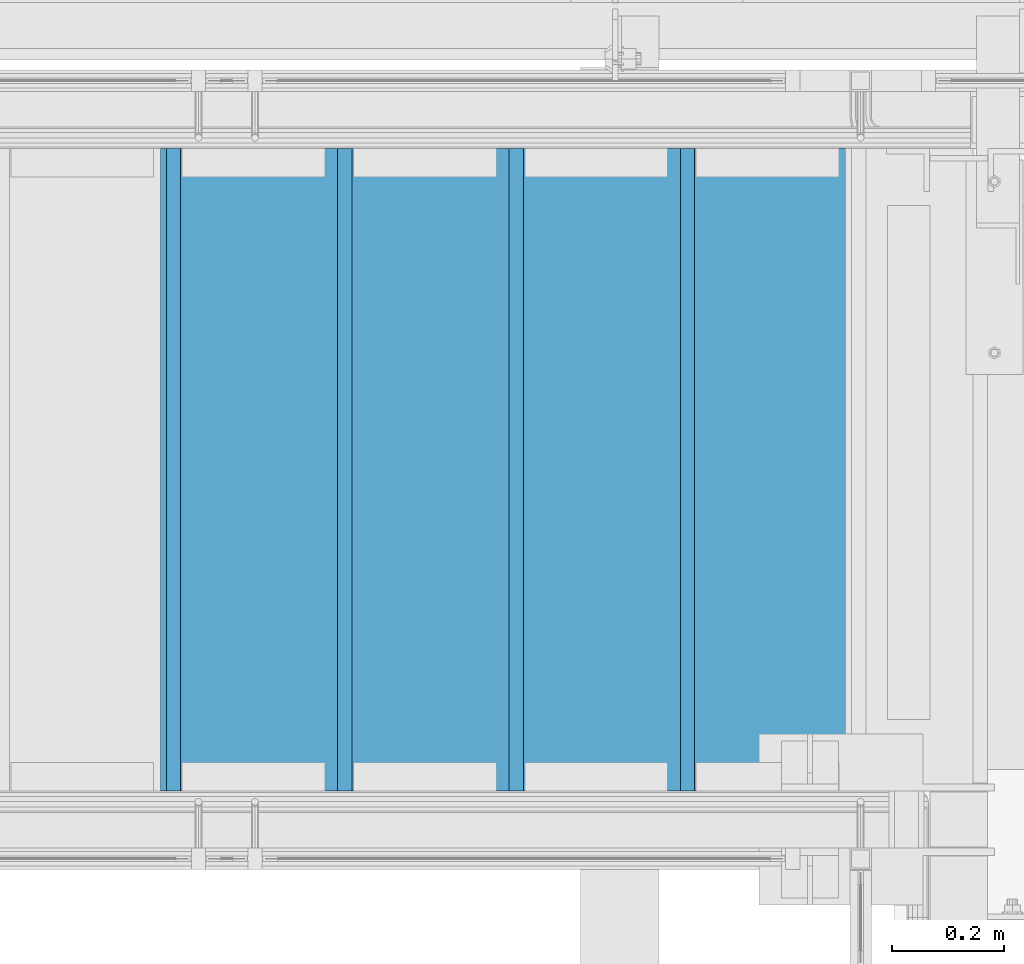
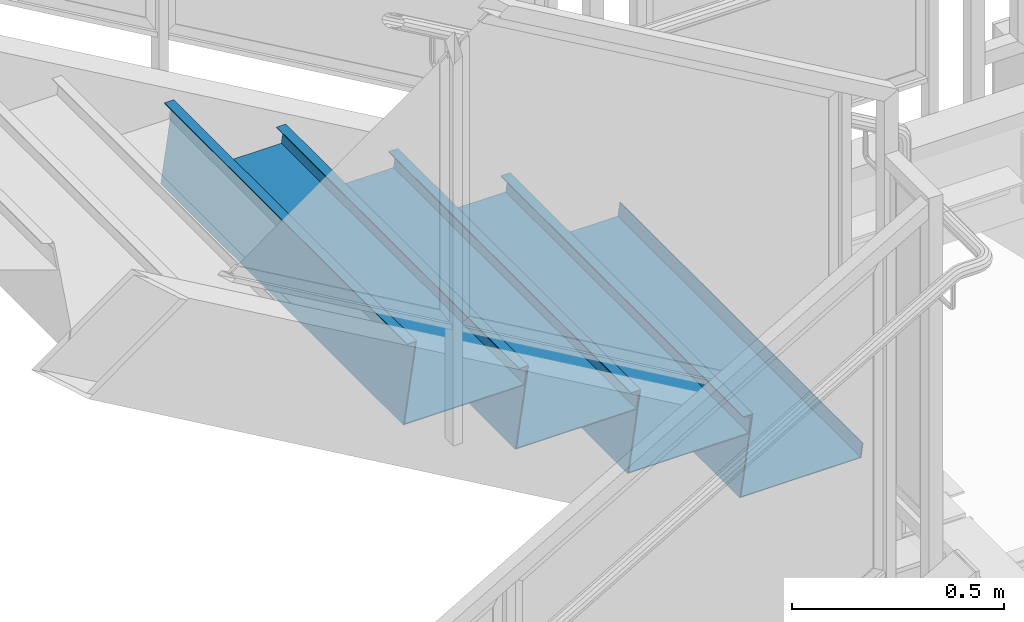
# One storey, part 796 of 1179: 4 beams, 1 element without a shape of its own.
"""IFC2X3 building model written with IfcOpenShell, lengths in millimetres."""

from ifc_helpers import new_model, si_unit, frame, origin_with_axes, place, context, subcontext, project, spatial, faceted_brep, material, type_object, element, aggregate, save


model = new_model("IFC2X3")

# Units and contexts
model_context = context("Model", 3, precision=1e-05, world=origin_with_axes())
body_context = subcontext(model_context, "Body", "Model", "MODEL_VIEW")
ifc_project = project(units=[si_unit("LENGTHUNIT", "METRE", prefix="MILLI"), si_unit("AREAUNIT", "SQUARE_METRE"), si_unit("VOLUMEUNIT", "CUBIC_METRE"), si_unit("MASSUNIT", "GRAM", prefix="KILO"), si_unit("TIMEUNIT", "SECOND"), si_unit("PLANEANGLEUNIT", "RADIAN"), si_unit("SOLIDANGLEUNIT", "STERADIAN"), si_unit("THERMODYNAMICTEMPERATUREUNIT", "DEGREE_CELSIUS"), si_unit("LUMINOUSINTENSITYUNIT", "LUMEN")], contexts=[model_context])

# Site, building, storey
site_placement = place(None, origin_with_axes())
site = spatial("IfcSite", under=ifc_project, at=site_placement, CompositionType="ELEMENT")
building_placement = place(site_placement, origin_with_axes())
building = spatial("IfcBuilding", under=site, at=building_placement, Name="Undefined", CompositionType="ELEMENT")
storey_placement = place(building_placement, origin_with_axes())
storey = spatial("IfcBuildingStorey", under=building, at=storey_placement, Name="Undefined", CompositionType="ELEMENT", Elevation=0.0)

# Assembly, beams
assembly_placement = place(storey_placement, origin_with_axes())
assembly = element("IfcElementAssembly", 1, at=assembly_placement, inside=storey, Name="STAIR", AssemblyPlace="NOTDEFINED", PredefinedType="RIGID_FRAME")
ifc_material = material(Name="STEEL/A36")
beam_type = type_object("IfcBeamType", PredefinedType="NOTDEFINED")
beam_1_placement = place(assembly_placement, frame((21609.0500003617, 40373.3000001154, 2998.82041641852), z_axis=(0.0, 1.0, 0.0), x_axis=(1.0, 0.0, 0.0)))
beam_1 = element("IfcBeam", 2, at=beam_1_placement, type_object=beam_type, material=ifc_material, Name="TREAD", context=body_context, shape_type="Brep", body=[
    faceted_brep([(0.0, -1.28999999999996, -571.5), (0.0, -1.28999999999996, 571.5), (0.0, 1.28999999999996, 571.5), (0.0, 1.28999999999996, -571.5), (22.4220799334253, 1.28999999999996, 571.5), (22.4220799334253, 1.28999999999996, -571.5), (25.4000000000015, -1.28999999999996, -571.5), (25.4000000000015, -1.28999999999996, 571.5), (-10.2894642965184, 228.56708328371, 571.5), (-10.2894642965184, 228.56708328371, -571.5), (-7.31154422994223, 225.98708328371, -571.5), (-7.31154422994223, 225.98708328371, 571.5), (319.911141878769, 228.56708328371, 571.5), (319.911141878769, 228.56708328371, -571.5), (317.675890478069, 225.98708328371, -571.5), (317.675890478069, 225.98708328371, 571.5), (325.657303794516, 188.643229151176, 571.5), (325.657303794516, 188.643229151176, -571.5), (323.103618368372, 188.27568222317, 571.5), (323.103618368372, 188.27568222317, -571.5)], [[[0, 1, 2, 3]], [[3, 2, 4, 5]], [[1, 0, 6, 7]], [[5, 4, 8, 9]], [[7, 6, 10, 11]], [[9, 8, 12, 13]], [[11, 10, 14, 15]], [[13, 12, 16, 17]], [[12, 8, 4, 2, 1, 7, 11, 15, 18, 16]], [[15, 14, 19, 18]], [[14, 10, 6, 0, 3, 5, 9, 13, 17, 19]], [[18, 19, 17, 16]]]),
])
beam_2_placement = place(assembly_placement, frame((21913.8500003543, 40373.3000001154, 2822.34333313482), z_axis=(0.0, 1.0, 0.0), x_axis=(1.0, 0.0, 0.0)))
beam_2 = element("IfcBeam", 3, at=beam_2_placement, type_object=beam_type, material=ifc_material, Name="TREAD", context=body_context, shape_type="Brep", body=[
    faceted_brep([(0.0, -1.28999999999996, -571.5), (0.0, -1.28999999999996, 571.5), (0.0, 1.28999999999996, 571.5), (0.0, 1.28999999999996, -571.5), (22.4220799334253, 1.28999999999996, 571.5), (22.4220799334253, 1.28999999999996, -571.5), (25.4000000000015, -1.28999999999996, -571.5), (25.4000000000015, -1.28999999999996, 571.5), (-10.2894642965184, 228.56708328371, 571.5), (-10.2894642965184, 228.56708328371, -571.5), (-7.31154422994223, 225.98708328371, -571.5), (-7.31154422994223, 225.98708328371, 571.5), (319.911141878769, 228.56708328371, 571.5), (319.911141878769, 228.56708328371, -571.5), (317.675890478069, 225.98708328371, -571.5), (317.675890478069, 225.98708328371, 571.5), (325.657303794516, 188.643229151176, 571.5), (325.657303794516, 188.643229151176, -571.5), (323.103618368372, 188.27568222317, 571.5), (323.103618368372, 188.27568222317, -571.5)], [[[0, 1, 2, 3]], [[3, 2, 4, 5]], [[1, 0, 6, 7]], [[5, 4, 8, 9]], [[7, 6, 10, 11]], [[9, 8, 12, 13]], [[11, 10, 14, 15]], [[13, 12, 16, 17]], [[12, 8, 4, 2, 1, 7, 11, 15, 18, 16]], [[15, 14, 19, 18]], [[14, 10, 6, 0, 3, 5, 9, 13, 17, 19]], [[18, 19, 17, 16]]]),
])
beam_3_placement = place(assembly_placement, frame((22218.6500003468, 40373.3000001154, 2645.86624985111), z_axis=(0.0, 1.0, 0.0), x_axis=(1.0, 0.0, 0.0)))
beam_3 = element("IfcBeam", 4, at=beam_3_placement, type_object=beam_type, material=ifc_material, Name="TREAD", context=body_context, shape_type="Brep", body=[
    faceted_brep([(0.0, -1.28999999999996, -571.5), (0.0, -1.28999999999996, 571.5), (0.0, 1.28999999999996, 571.5), (0.0, 1.28999999999996, -571.5), (22.4220799334253, 1.28999999999996, 571.5), (22.4220799334253, 1.28999999999996, -571.5), (25.4000000000015, -1.28999999999996, -571.5), (25.4000000000015, -1.28999999999996, 571.5), (-10.2894642965184, 228.56708328371, 571.5), (-10.2894642965184, 228.56708328371, -571.5), (-7.31154422994223, 225.98708328371, -571.5), (-7.31154422994223, 225.98708328371, 571.5), (319.911141878769, 228.56708328371, 571.5), (319.911141878769, 228.56708328371, -571.5), (317.675890478069, 225.98708328371, -571.5), (317.675890478069, 225.98708328371, 571.5), (325.657303794516, 188.643229151176, 571.5), (325.657303794516, 188.643229151176, -571.5), (323.103618368372, 188.27568222317, 571.5), (323.103618368372, 188.27568222317, -571.5)], [[[0, 1, 2, 3]], [[3, 2, 4, 5]], [[1, 0, 6, 7]], [[5, 4, 8, 9]], [[7, 6, 10, 11]], [[9, 8, 12, 13]], [[11, 10, 14, 15]], [[13, 12, 16, 17]], [[12, 8, 4, 2, 1, 7, 11, 15, 18, 16]], [[15, 14, 19, 18]], [[14, 10, 6, 0, 3, 5, 9, 13, 17, 19]], [[18, 19, 17, 16]]]),
])
beam_4_placement = place(assembly_placement, frame((22523.4500003394, 40373.3000001154, 2469.3891665674), z_axis=(0.0, 1.0, 0.0), x_axis=(1.0, 0.0, 0.0)))
beam_4 = element("IfcBeam", 5, at=beam_4_placement, type_object=beam_type, material=ifc_material, Name="TREAD", context=body_context, shape_type="Brep", body=[
    faceted_brep([(0.0, -1.28999999999996, -571.5), (0.0, -1.28999999999996, 571.5), (0.0, 1.28999999999996, 571.5), (0.0, 1.28999999999996, -571.5), (22.4220799334253, 1.28999999999996, 571.5), (22.4220799334253, 1.28999999999996, -571.5), (25.4000000000015, -1.28999999999996, -571.5), (25.4000000000015, -1.28999999999996, 571.5), (-10.2894642965184, 228.56708328371, 571.5), (-10.2894642965184, 228.56708328371, -571.5), (-7.31154422994223, 225.98708328371, -571.5), (-7.31154422994223, 225.98708328371, 571.5), (319.911141878769, 228.56708328371, 571.5), (319.911141878769, 228.56708328371, -571.5), (317.675890478069, 225.98708328371, -571.5), (317.675890478069, 225.98708328371, 571.5), (325.657303794516, 188.643229151176, 571.5), (325.657303794516, 188.643229151176, -571.5), (323.103618368372, 188.27568222317, 571.5), (323.103618368372, 188.27568222317, -571.5)], [[[0, 1, 2, 3]], [[3, 2, 4, 5]], [[1, 0, 6, 7]], [[5, 4, 8, 9]], [[7, 6, 10, 11]], [[9, 8, 12, 13]], [[11, 10, 14, 15]], [[13, 12, 16, 17]], [[12, 8, 4, 2, 1, 7, 11, 15, 18, 16]], [[15, 14, 19, 18]], [[14, 10, 6, 0, 3, 5, 9, 13, 17, 19]], [[18, 19, 17, 16]]]),
])
aggregate(assembly, [beam_1, beam_2, beam_3, beam_4])

save(model, "model.ifc")
